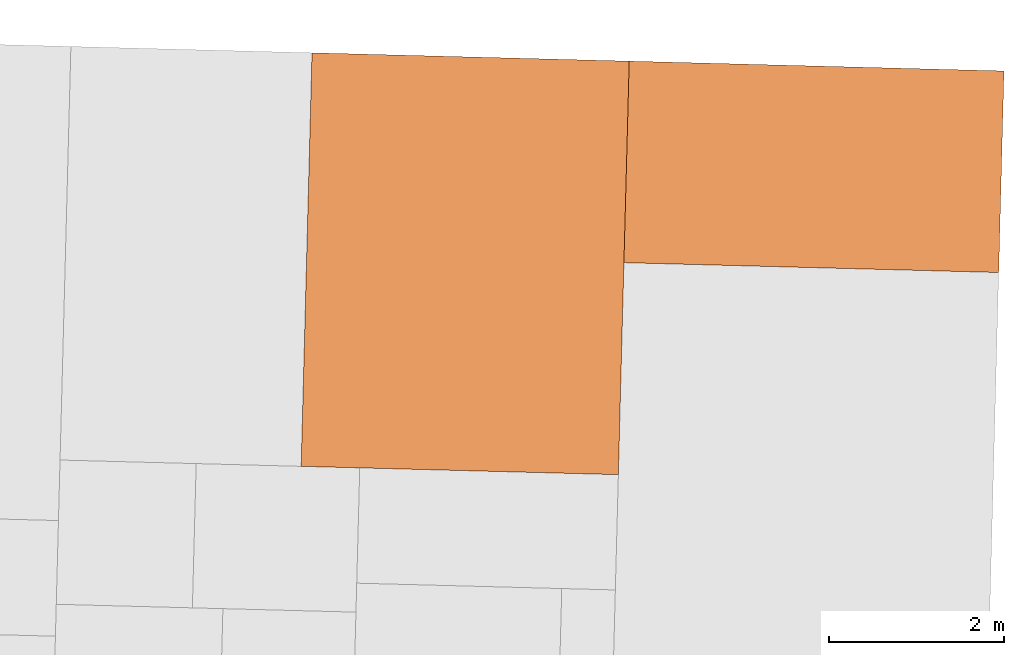
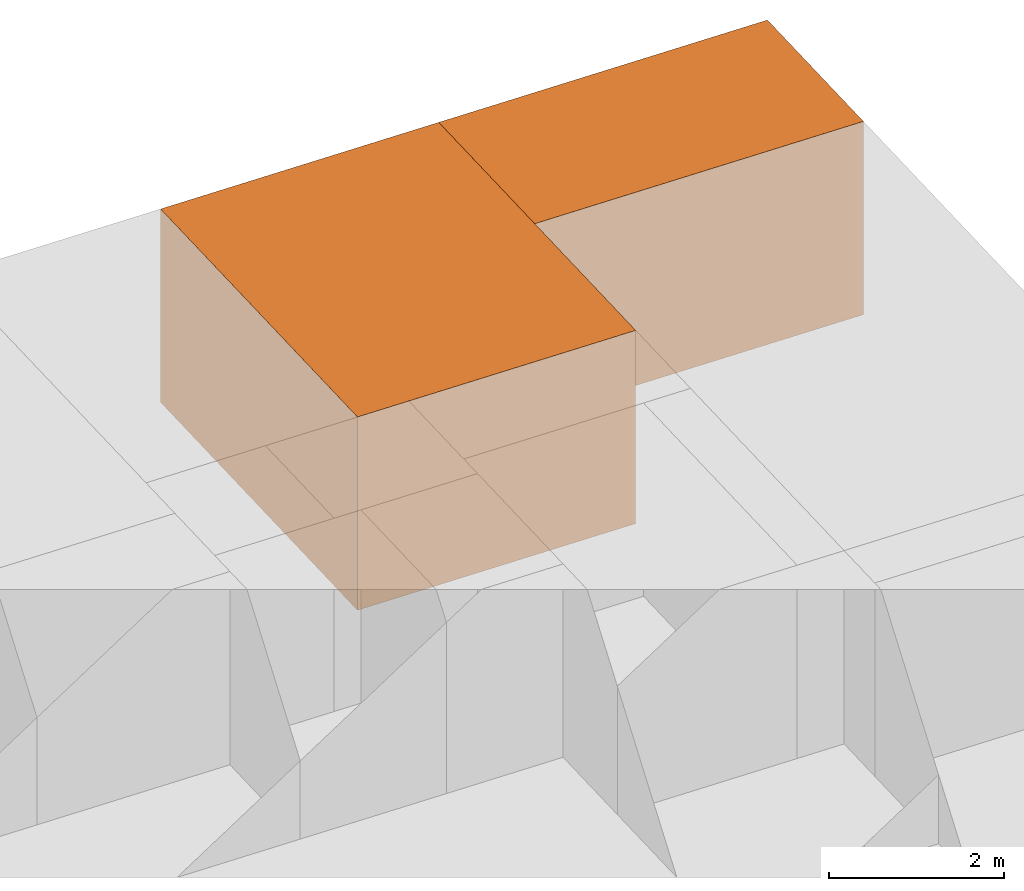
# One storey, part 2 of 2: 2 proxies.
"""IFC2X3 building model written with IfcOpenShell, lengths in metres."""

from ifc_helpers import new_model, entity, si_unit, converted_unit, derived_unit, direction, frame, origin, origin_2d_with_axis, place, context, subcontext, project, spatial, rectangle, extrude, source, transform, mapped, material, type_object, type_shapes, element, save


model = new_model("IFC2X3")

# Units and contexts
model_context = context("Model", 3, precision=1e-05, world=origin(), true_north=direction((-0.999656054706472, -0.0262254130318397)))
body_context = subcontext(model_context, "Body", "Model", "MODEL_VIEW")
ifc_project = project(units=[si_unit("LENGTHUNIT", "METRE"), si_unit("AREAUNIT", "SQUARE_METRE"), si_unit("VOLUMEUNIT", "CUBIC_METRE"), converted_unit("PLANEANGLEUNIT", "DEGREE", entity("IfcRatioMeasure", 0.0174532925199433), si_unit("PLANEANGLEUNIT", "RADIAN"), dimensions=[0, 0, 0, 0, 0, 0, 0]), si_unit("MASSUNIT", "GRAM", prefix="KILO"), derived_unit("MASSDENSITYUNIT", [(si_unit("MASSUNIT", "GRAM", prefix="KILO"), 1), (si_unit("LENGTHUNIT", "METRE"), -3)]), si_unit("TIMEUNIT", "SECOND"), si_unit("FREQUENCYUNIT", "HERTZ"), si_unit("THERMODYNAMICTEMPERATUREUNIT", "DEGREE_CELSIUS"), derived_unit("THERMALTRANSMITTANCEUNIT", [(si_unit("MASSUNIT", "GRAM", prefix="KILO"), 1), (si_unit("THERMODYNAMICTEMPERATUREUNIT", "KELVIN"), -1), (si_unit("TIMEUNIT", "SECOND"), -3)]), derived_unit("VOLUMETRICFLOWRATEUNIT", [(si_unit("LENGTHUNIT", "METRE"), 3), (si_unit("TIMEUNIT", "SECOND"), -1)]), si_unit("ELECTRICCURRENTUNIT", "AMPERE"), si_unit("ELECTRICVOLTAGEUNIT", "VOLT"), si_unit("POWERUNIT", "WATT"), si_unit("FORCEUNIT", "NEWTON", prefix="KILO"), si_unit("ILLUMINANCEUNIT", "LUX"), si_unit("LUMINOUSFLUXUNIT", "LUMEN"), si_unit("LUMINOUSINTENSITYUNIT", "CANDELA"), derived_unit("USERDEFINED", [(si_unit("MASSUNIT", "GRAM", prefix="KILO"), -1), (si_unit("LENGTHUNIT", "METRE"), -2), (si_unit("TIMEUNIT", "SECOND"), 3), (si_unit("LUMINOUSFLUXUNIT", "LUMEN"), 1)]), derived_unit("LINEARVELOCITYUNIT", [(si_unit("LENGTHUNIT", "METRE"), 1), (si_unit("TIMEUNIT", "SECOND"), -1)]), si_unit("PRESSUREUNIT", "PASCAL"), derived_unit("USERDEFINED", [(si_unit("LENGTHUNIT", "METRE"), -2), (si_unit("MASSUNIT", "GRAM", prefix="KILO"), 1), (si_unit("TIMEUNIT", "SECOND"), -2)])], contexts=[model_context])

# Site, building, storey
site_placement = place(None, frame((0.0, 0.0, 0.0), z_axis=(0.0, 0.0, 1.0), x_axis=(-0.0262254130318394, -0.999656054706472, 0.0)))
site = spatial("IfcSite", under=ifc_project, at=site_placement, CompositionType="ELEMENT")
building_placement = place(site_placement, origin())
building = spatial("IfcBuilding", under=site, at=building_placement, CompositionType="ELEMENT")
storey_placement = place(building_placement, origin())
storey = spatial("IfcBuildingStorey", under=building, at=storey_placement, Name="0EG", CompositionType="ELEMENT", Elevation=0.0)

# Proxies
ifc_material_1 = material(Name="004_Balcony")
building_element_proxy_type_1 = type_object("IfcBuildingElementProxyType", PredefinedType="NOTDEFINED", material=ifc_material_1)
shared_shape_1 = source(origin(), body_context, "Body", "SweptSolid", [
    extrude(rectangle(XDim=2.30147058823531, YDim=4.27941176470587, at=origin_2d_with_axis()), frame((0.0, 0.0, 0.0), z_axis=(0.0, 0.0, 1.0), x_axis=(-1.0, 0.0, 0.0)), (0.0, 0.0, 1.0), 2.7),
])
type_shapes(building_element_proxy_type_1, [shared_shape_1])
proxy_1_placement = place(storey_placement, frame((-3.47983786124327, -30.1803742732614, 0.0)))
element("IfcBuildingElementProxy", 1, at=proxy_1_placement, inside=storey, type_object=building_element_proxy_type_1, material=ifc_material_1, Name="Segment_new:S", context=body_context, shape_type="MappedRepresentation", body=[
    mapped(shared_shape_1, transform((0.0, 0.0, 0.0), scale=1.0)),
])
ifc_material_2 = material(Name="001_Bedroom")
building_element_proxy_type_2 = type_object("IfcBuildingElementProxyType", PredefinedType="NOTDEFINED", material=ifc_material_2)
shared_shape_2 = source(origin(), body_context, "Body", "SweptSolid", [
    extrude(rectangle(XDim=4.72205882352941, YDim=3.62205882352943, at=origin_2d_with_axis()), frame((0.0, 0.0, 0.0), z_axis=(0.0, 0.0, 1.0), x_axis=(-1.0, 0.0, 0.0)), (0.0, 0.0, 1.0), 2.7),
])
type_shapes(building_element_proxy_type_2, [shared_shape_2])
proxy_2_placement = place(storey_placement, frame((-2.26954374359622, -34.1311095673791, 0.0)))
element("IfcBuildingElementProxy", 2, at=proxy_2_placement, inside=storey, type_object=building_element_proxy_type_2, material=ifc_material_2, Name="Segment_new:S_Sch", context=body_context, shape_type="MappedRepresentation", body=[
    mapped(shared_shape_2, transform((0.0, 0.0, 0.0), scale=1.0)),
])

save(model, "model.ifc")
